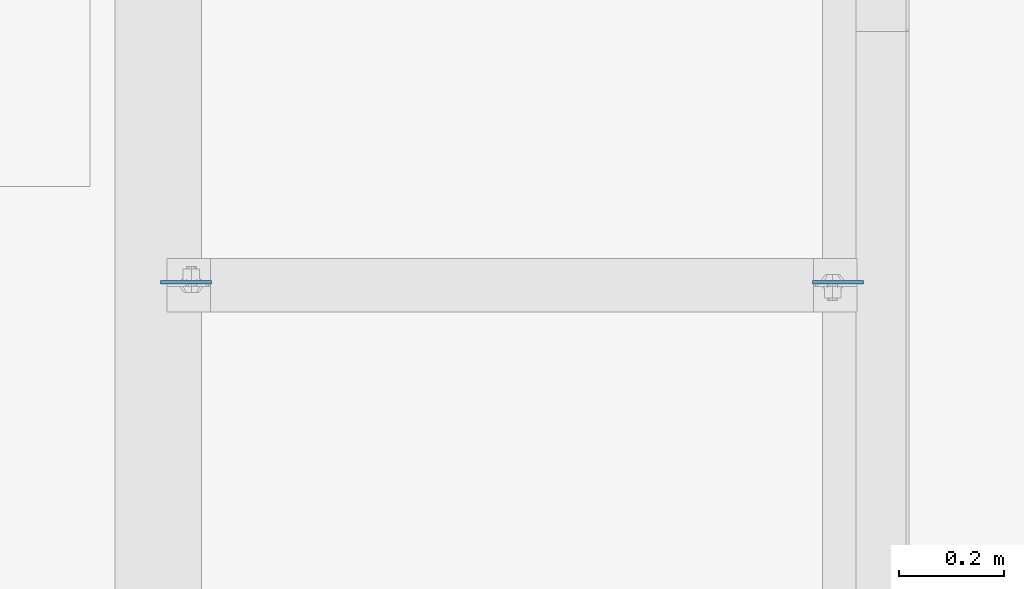
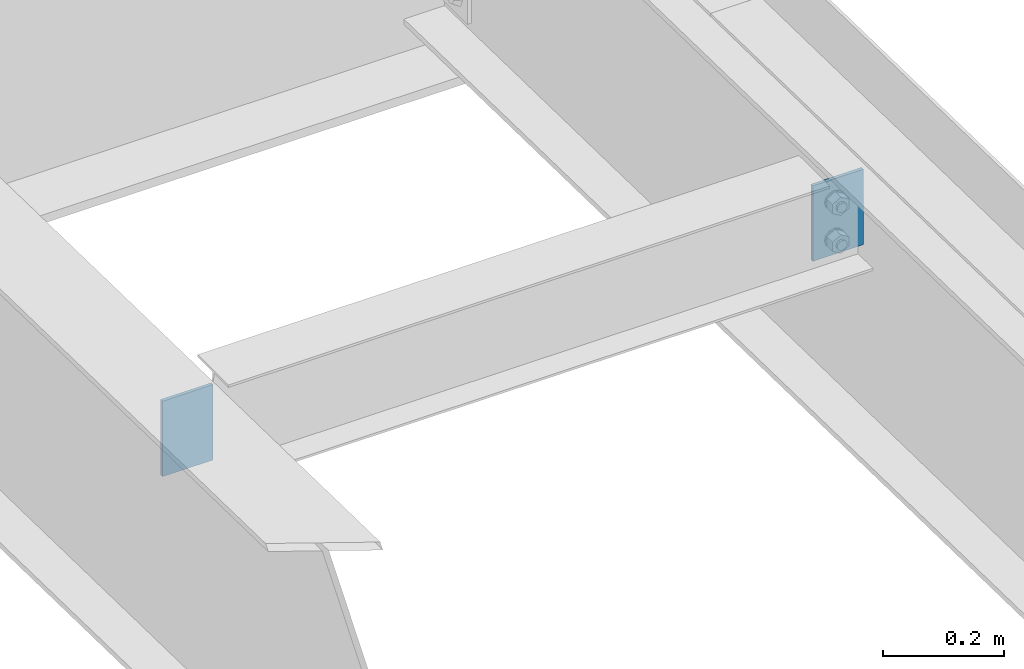
# One storey, part 1574 of 1763: 2 plates, 2 elements without a shape of their own.
"""IFC2X3 building model written with IfcOpenShell, lengths in millimetres."""

import ifcopenshell
import ifcopenshell.guid

model = None  # the IFC model being written
_history = None  # IfcOwnerHistory: only IFC2X3 demands one
_inside = {}  # id of a spatial element -> (the spatial element, [elements in it])
_under = {}  # id of a project, library or spatial element -> (it, [spatial elements below it])
_declared = {}  # id of a project -> (the project, [libraries it declares])
_typed = {}  # id of a type object -> (the type object, [elements of that type])
_made_of = {}  # id of a material, layer set ... -> (it, [elements and type objects made of it])


def new_model(schema):
    """Start an empty IFC model of exactly this schema.

    Asked for "IFC4X3", IfcOpenShell would pick the latest addendum, in which some entities
    have other attributes; the version numbers below select the first issue.
    IFC2X3 requires an IfcOwnerHistory on every rooted entity: one is made here for all.
    """
    global model, _history
    if schema == "IFC4X3":
        model = ifcopenshell.file(schema_version=(4, 3, 0, 0))
    else:
        model = ifcopenshell.file(schema=schema)
    _inside.clear()
    _under.clear()
    _declared.clear()
    _typed.clear()
    _made_of.clear()
    _history = None
    if model.schema == "IFC2X3":
        org = make("IfcOrganization", Name="unknown")
        user = make(
            "IfcPersonAndOrganization",
            ThePerson=make("IfcPerson", FamilyName="unknown"),
            TheOrganization=org,
        )
        app = make(
            "IfcApplication",
            ApplicationDeveloper=org,
            Version="unknown",
            ApplicationFullName="unknown",
            ApplicationIdentifier="unknown",
        )
        _history = make(
            "IfcOwnerHistory",
            OwningUser=user,
            OwningApplication=app,
            ChangeAction="ADDED",
            CreationDate=0,
        )
    return model


def make(cls, **values):
    """One entity of the class cls with the attributes given. An attribute that is None is left unset."""
    return model.create_entity(
        cls, **{name: value for name, value in values.items() if value is not None}
    )


def rooted(cls, **values):
    """An entity with a GlobalId (a new one), such as an element, a storey or a relation."""
    return make(cls, GlobalId=ifcopenshell.guid.new(), OwnerHistory=_history, **values)


def si_unit(unit_type, name, prefix=None):
    """IfcSIUnit, for example si_unit("LENGTHUNIT", "METRE", prefix="MILLI")."""
    return make("IfcSIUnit", UnitType=unit_type, Prefix=prefix, Name=name)


def assignment(units):
    """IfcUnitAssignment: the units of a project."""
    return None if units is None else make("IfcUnitAssignment", Units=units)


def point(xyz):
    """IfcCartesianPoint."""
    return None if xyz is None else make("IfcCartesianPoint", Coordinates=xyz)


def direction(xyz):
    """IfcDirection."""
    return None if xyz is None else make("IfcDirection", DirectionRatios=xyz)


def frame(location, z_axis=None, x_axis=None):
    """IfcAxis2Placement3D, a coordinate frame: its origin and axes. An axis left out is left unset."""
    return make(
        "IfcAxis2Placement3D",
        Location=point(location),
        Axis=direction(z_axis),
        RefDirection=direction(x_axis),
    )


def origin_with_axes():
    """The frame at (0, 0, 0) with the z axis (0, 0, 1) and the x axis (1, 0, 0) written out."""
    return frame((0.0, 0.0, 0.0), z_axis=(0.0, 0.0, 1.0), x_axis=(1.0, 0.0, 0.0))


def place(relative_to, where):
    """IfcLocalPlacement: puts the frame where relative to a parent placement (None: the world)."""
    return make(
        "IfcLocalPlacement", PlacementRelTo=relative_to, RelativePlacement=where
    )


def context(
    kind, dimensions, precision=None, world=None, true_north=None, identifier=None
):
    """IfcGeometricRepresentationContext, for example the 3D "Model" context."""
    return make(
        "IfcGeometricRepresentationContext",
        ContextIdentifier=identifier,
        ContextType=kind,
        CoordinateSpaceDimension=dimensions,
        Precision=precision,
        WorldCoordinateSystem=world,
        TrueNorth=true_north,
    )


def subcontext(parent, identifier, kind, view, scale=None):
    """IfcGeometricRepresentationSubContext, for example "Body" below "Model"."""
    return make(
        "IfcGeometricRepresentationSubContext",
        ContextIdentifier=identifier,
        ContextType=kind,
        ParentContext=parent,
        TargetScale=scale,
        TargetView=view,
    )


def project(units=None, contexts=None):
    """IfcProject with its units and contexts."""
    return rooted(
        "IfcProject",
        Name="project",
        RepresentationContexts=contexts,
        UnitsInContext=assignment(units),
    )


def spatial(cls, under=None, at=None, **own):
    """A site, building, storey or space (cls), placed at a placement, below another one or the project."""
    s = rooted(cls, ObjectPlacement=at, **own)
    if under is not None:
        _under.setdefault(under.id(), (under, []))[1].append(s)
    return s


def faces_of(points, faces, orient=None, outer=None):
    """IfcFace entities. A face is a list of loops; a loop is a list of indices into points, from 0.

    orient and outer hold one flag for each loop. By default every Orientation is true, the
    first loop of a face is its IfcFaceOuterBound and the others are IfcFaceBound.
    """
    made = []
    for i, loops in enumerate(faces):
        bounds = []
        for j, loop in enumerate(loops):
            is_outer = j == 0 if outer is None else outer[i][j]
            bounds.append(
                make(
                    "IfcFaceOuterBound" if is_outer else "IfcFaceBound",
                    Bound=make("IfcPolyLoop", Polygon=[points[k] for k in loop]),
                    Orientation=True if orient is None else orient[i][j],
                )
            )
        made.append(make("IfcFace", Bounds=bounds))
    return made


def faceted_brep(points, faces, orient=None, outer=None, voids=None):
    """IfcFacetedBrep: a solid bounded by flat faces; with voids (closed shells), ...WithVoids."""
    shared = [point(p) for p in points]
    hull = make("IfcClosedShell", CfsFaces=faces_of(shared, faces, orient, outer))
    if voids is None:
        return make("IfcFacetedBrep", Outer=hull)
    return make(
        "IfcFacetedBrepWithVoids",
        Outer=hull,
        Voids=[
            make(cls, CfsFaces=faces_of(shared, fs, o, b)) for cls, fs, o, b in voids
        ],
    )


def shape(context_of_items, identifier, shape_type, items):
    """IfcShapeRepresentation: the items that make up one representation, for example the "Body"."""
    return make(
        "IfcShapeRepresentation",
        ContextOfItems=context_of_items,
        RepresentationIdentifier=identifier,
        RepresentationType=shape_type,
        Items=items,
    )


def material(Name=None, Category=None):
    """IfcMaterial."""
    return make("IfcMaterial", Name=Name, Category=Category)


def made_of(thing, what):
    """Note that an element or type object is made of a material, layer set ...; save() writes the relation."""
    if what is not None:
        _made_of.setdefault(what.id(), (what, []))[1].append(thing)
    return thing


def type_object(cls, material=None, **own):
    """A type object (cls), such as IfcWallType, which elements share."""
    return made_of(rooted(cls, **own), material)


def element(
    cls,
    number,
    at=None,
    inside=None,
    cuts=None,
    type_object=None,
    material=None,
    context=None,
    identifier="Body",
    shape_type=None,
    held_by="IfcProductDefinitionShape",
    body=None,
    shapes=None,
    **own,
):
    """One element of the class cls, such as IfcWall. Its Tag is "e" and its number.

    at: its placement. inside: the storey or other place that contains it. cuts: it is an
    opening in that element (IfcRelVoidsElement). A single representation is given by context,
    identifier, shape_type and body (its items); several are given by shapes. held_by: the class
    of the entity that holds the representations. save() writes the other relations.
    """
    e = rooted(cls, Tag="e%d" % number, ObjectPlacement=at, **own)
    if body is not None:
        shapes = [shape(context, identifier, shape_type, body)]
    if shapes is not None:
        e.Representation = make(held_by, Representations=shapes)
    if inside is not None:
        _inside.setdefault(inside.id(), (inside, []))[1].append(e)
    if cuts is not None:
        rooted(
            "IfcRelVoidsElement", RelatingBuildingElement=cuts, RelatedOpeningElement=e
        )
    if type_object is not None:
        _typed.setdefault(type_object.id(), (type_object, []))[1].append(e)
    return made_of(e, material)


def aggregate(whole, parts):
    """IfcRelAggregates: a whole, such as a stair, and the parts it consists of."""
    return rooted("IfcRelAggregates", RelatingObject=whole, RelatedObjects=parts)


def save(model, path):
    """Write the relations noted so far, then the file.

    IfcRelAggregates (storeys below a building ...), IfcRelContainedInSpatialStructure (elements
    in a storey), IfcRelDefinesByType, IfcRelAssociatesMaterial and IfcRelDeclares: one each for
    every whole, place, type object, material and project.
    """
    for whole, parts in _under.values():
        aggregate(whole, parts)
    for where, things in _inside.values():
        rooted(
            "IfcRelContainedInSpatialStructure",
            RelatedElements=things,
            RelatingStructure=where,
        )
    for kind, things in _typed.values():
        rooted("IfcRelDefinesByType", RelatedObjects=things, RelatingType=kind)
    for what, things in _made_of.values():
        rooted("IfcRelAssociatesMaterial", RelatedObjects=things, RelatingMaterial=what)
    for by, libraries in _declared.values():
        rooted("IfcRelDeclares", RelatingContext=by, RelatedDefinitions=libraries)
    model.write(path)


model = new_model("IFC2X3")

# Units and contexts
model_context = context("Model", 3, precision=1e-05, world=origin_with_axes())
body_context = subcontext(model_context, "Body", "Model", "MODEL_VIEW")
ifc_project = project(units=[si_unit("LENGTHUNIT", "METRE", prefix="MILLI"), si_unit("AREAUNIT", "SQUARE_METRE"), si_unit("VOLUMEUNIT", "CUBIC_METRE"), si_unit("MASSUNIT", "GRAM", prefix="KILO"), si_unit("TIMEUNIT", "SECOND"), si_unit("PLANEANGLEUNIT", "RADIAN"), si_unit("SOLIDANGLEUNIT", "STERADIAN"), si_unit("THERMODYNAMICTEMPERATUREUNIT", "DEGREE_CELSIUS"), si_unit("LUMINOUSINTENSITYUNIT", "LUMEN")], contexts=[model_context])

# Site, building, storey
site_placement = place(None, origin_with_axes())
site = spatial("IfcSite", under=ifc_project, at=site_placement, CompositionType="ELEMENT")
building_placement = place(site_placement, origin_with_axes())
building = spatial("IfcBuilding", under=site, at=building_placement, Name="Undefined", CompositionType="ELEMENT")
storey_placement = place(building_placement, origin_with_axes())
storey = spatial("IfcBuildingStorey", under=building, at=storey_placement, Name="Undefined", CompositionType="ELEMENT", Elevation=0.0)

# Assembly, plate
assembly_1_placement = place(storey_placement, origin_with_axes())
assembly_1 = element("IfcElementAssembly", 1, at=assembly_1_placement, inside=storey, Name="BEAM", AssemblyPlace="NOTDEFINED", PredefinedType="RIGID_FRAME")
ifc_material = material(Name="STEEL/A36")
plate_type = type_object("IfcPlateType", PredefinedType="NOTDEFINED")
plate_1_placement = place(assembly_1_placement, frame((-22673.6997736983, 12288.9943543081, 11629.40774776), z_axis=(1.0, 0.0, 0.0), x_axis=(0.0, 0.0, -1.0)))
plate_1 = element("IfcPlate", 2, at=plate_1_placement, type_object=plate_type, material=ifc_material, Name="PLATE", context=body_context, shape_type="Brep", body=[
    faceted_brep([(1.81898940354586e-12, -3.17500000000291, 0.0), (0.0, -3.17499999999927, 96.8375015258789), (0.0, 3.17499999999927, 96.8375015258789), (-1.81898940354586e-12, 3.17499999997381, 0.0), (152.399993896484, -3.17499999999927, 96.8375015258789), (152.399993896484, 3.17499999999927, 96.8375015258789), (152.399993896484, -3.17500000000291, 0.0), (152.399993896484, 3.17500000000291, 0.0)], [[[0, 1, 2, 3]], [[1, 4, 5, 2]], [[4, 6, 7, 5]], [[6, 0, 3, 7]], [[5, 7, 3, 2]], [[6, 4, 1, 0]]]),
])
aggregate(assembly_1, [plate_1])

assembly_2_placement = place(storey_placement, origin_with_axes())
assembly_2 = element("IfcElementAssembly", 3, at=assembly_2_placement, inside=storey, Name="BEAM", AssemblyPlace="NOTDEFINED", PredefinedType="RIGID_FRAME")
plate_2_placement = place(assembly_2_placement, frame((-21333.8497736983, 12288.9943543081, 11629.40774776), z_axis=(-1.0, 0.0, 0.0), x_axis=(0.0, 0.0, -1.0)))
plate_2 = element("IfcPlate", 4, at=plate_2_placement, type_object=plate_type, material=ifc_material, Name="PLATE", context=body_context, shape_type="Brep", body=[
    faceted_brep([(1.81898940354586e-12, -3.17500000000291, 0.0), (0.0, -3.17499999999927, 96.8375015258789), (0.0, 3.17499999999927, 96.8375015258789), (-1.81898940354586e-12, 3.17499999997381, 0.0), (152.399993896484, -3.17499999999927, 96.8375015258789), (152.399993896484, 3.17499999999927, 96.8375015258789), (152.399993896484, -3.17500000000291, 0.0), (152.399993896484, 3.17500000000291, 0.0)], [[[0, 1, 2, 3]], [[1, 4, 5, 2]], [[4, 6, 7, 5]], [[6, 0, 3, 7]], [[5, 7, 3, 2]], [[6, 4, 1, 0]]]),
])
aggregate(assembly_2, [plate_2])

save(model, "model.ifc")
